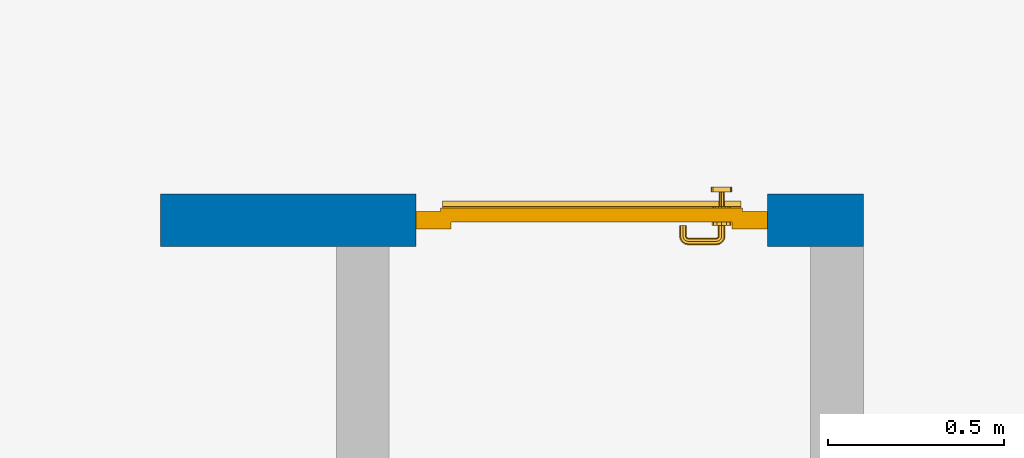
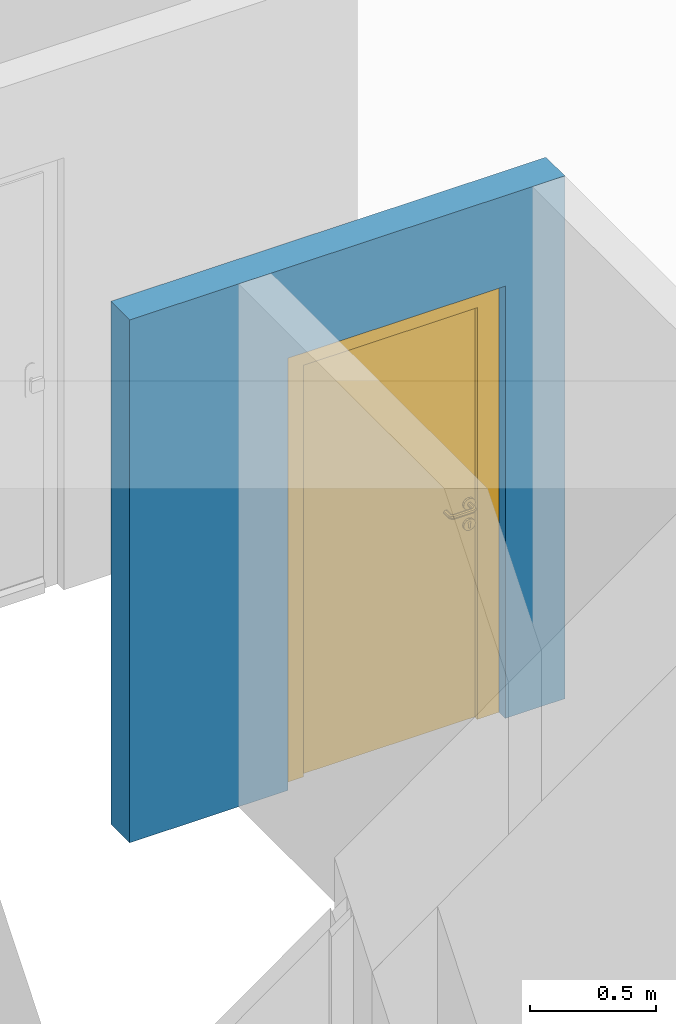
# One storey, part 23 of 54: 1 door, 1 wall, 1 opening.
"""IFC4 building model written with IfcOpenShell, lengths in metres."""

import ifcopenshell
import ifcopenshell.guid

model = None  # the IFC model being written
_history = None  # IfcOwnerHistory: only IFC2X3 demands one
_inside = {}  # id of a spatial element -> (the spatial element, [elements in it])
_under = {}  # id of a project, library or spatial element -> (it, [spatial elements below it])
_declared = {}  # id of a project -> (the project, [libraries it declares])
_typed = {}  # id of a type object -> (the type object, [elements of that type])
_made_of = {}  # id of a material, layer set ... -> (it, [elements and type objects made of it])


def new_model(schema):
    """Start an empty IFC model of exactly this schema.

    Asked for "IFC4X3", IfcOpenShell would pick the latest addendum, in which some entities
    have other attributes; the version numbers below select the first issue.
    IFC2X3 requires an IfcOwnerHistory on every rooted entity: one is made here for all.
    """
    global model, _history
    if schema == "IFC4X3":
        model = ifcopenshell.file(schema_version=(4, 3, 0, 0))
    else:
        model = ifcopenshell.file(schema=schema)
    _inside.clear()
    _under.clear()
    _declared.clear()
    _typed.clear()
    _made_of.clear()
    _history = None
    if model.schema == "IFC2X3":
        org = make("IfcOrganization", Name="unknown")
        user = make(
            "IfcPersonAndOrganization",
            ThePerson=make("IfcPerson", FamilyName="unknown"),
            TheOrganization=org,
        )
        app = make(
            "IfcApplication",
            ApplicationDeveloper=org,
            Version="unknown",
            ApplicationFullName="unknown",
            ApplicationIdentifier="unknown",
        )
        _history = make(
            "IfcOwnerHistory",
            OwningUser=user,
            OwningApplication=app,
            ChangeAction="ADDED",
            CreationDate=0,
        )
    return model


def make(cls, **values):
    """One entity of the class cls with the attributes given. An attribute that is None is left unset."""
    return model.create_entity(
        cls, **{name: value for name, value in values.items() if value is not None}
    )


def entity(cls, *values):
    """Any entity or typed value of the class cls, its attributes in the order of the schema. None: left unset."""
    e = model.create_entity(cls)
    for i, value in enumerate(values):
        if value is not None:
            e[i] = value
    return e


def rooted(cls, **values):
    """An entity with a GlobalId (a new one), such as an element, a storey or a relation."""
    return make(cls, GlobalId=ifcopenshell.guid.new(), OwnerHistory=_history, **values)


def si_unit(unit_type, name, prefix=None):
    """IfcSIUnit, for example si_unit("LENGTHUNIT", "METRE", prefix="MILLI")."""
    return make("IfcSIUnit", UnitType=unit_type, Prefix=prefix, Name=name)


def converted_unit(unit_type, name, factor, base, dimensions=None, offset=None):
    """IfcConversionBasedUnit, such as the inch: factor (a typed value) times the base unit."""
    return make(
        "IfcConversionBasedUnit"
        if offset is None
        else "IfcConversionBasedUnitWithOffset",
        ConversionOffset=offset,
        Dimensions=None
        if dimensions is None
        else entity("IfcDimensionalExponents", *dimensions),
        UnitType=unit_type,
        Name=name,
        ConversionFactor=make(
            "IfcMeasureWithUnit", ValueComponent=factor, UnitComponent=base
        ),
    )


def derived_unit(unit_type, elements):
    """IfcDerivedUnit: a product of units, each with its exponent."""
    return make(
        "IfcDerivedUnit",
        Elements=[
            make("IfcDerivedUnitElement", Unit=unit, Exponent=power)
            for unit, power in elements
        ],
        UnitType=unit_type,
    )


def assignment(units):
    """IfcUnitAssignment: the units of a project."""
    return None if units is None else make("IfcUnitAssignment", Units=units)


def point(xyz):
    """IfcCartesianPoint."""
    return None if xyz is None else make("IfcCartesianPoint", Coordinates=xyz)


def direction(xyz):
    """IfcDirection."""
    return None if xyz is None else make("IfcDirection", DirectionRatios=xyz)


def frame(location, z_axis=None, x_axis=None):
    """IfcAxis2Placement3D, a coordinate frame: its origin and axes. An axis left out is left unset."""
    return make(
        "IfcAxis2Placement3D",
        Location=point(location),
        Axis=direction(z_axis),
        RefDirection=direction(x_axis),
    )


def origin_with_axes():
    """The frame at (0, 0, 0) with the z axis (0, 0, 1) and the x axis (1, 0, 0) written out."""
    return frame((0.0, 0.0, 0.0), z_axis=(0.0, 0.0, 1.0), x_axis=(1.0, 0.0, 0.0))


def place(relative_to, where):
    """IfcLocalPlacement: puts the frame where relative to a parent placement (None: the world)."""
    return make(
        "IfcLocalPlacement", PlacementRelTo=relative_to, RelativePlacement=where
    )


def context(
    kind, dimensions, precision=None, world=None, true_north=None, identifier=None
):
    """IfcGeometricRepresentationContext, for example the 3D "Model" context."""
    return make(
        "IfcGeometricRepresentationContext",
        ContextIdentifier=identifier,
        ContextType=kind,
        CoordinateSpaceDimension=dimensions,
        Precision=precision,
        WorldCoordinateSystem=world,
        TrueNorth=true_north,
    )


def subcontext(parent, identifier, kind, view, scale=None):
    """IfcGeometricRepresentationSubContext, for example "Body" below "Model"."""
    return make(
        "IfcGeometricRepresentationSubContext",
        ContextIdentifier=identifier,
        ContextType=kind,
        ParentContext=parent,
        TargetScale=scale,
        TargetView=view,
    )


def project(units=None, contexts=None):
    """IfcProject with its units and contexts."""
    return rooted(
        "IfcProject",
        Name="project",
        RepresentationContexts=contexts,
        UnitsInContext=assignment(units),
    )


def spatial(cls, under=None, at=None, **own):
    """A site, building, storey or space (cls), placed at a placement, below another one or the project."""
    s = rooted(cls, ObjectPlacement=at, **own)
    if under is not None:
        _under.setdefault(under.id(), (under, []))[1].append(s)
    return s


def point_list(points):
    """IfcCartesianPointList2D or 3D."""
    cls = (
        "IfcCartesianPointList2D" if len(points[0]) == 2 else "IfcCartesianPointList3D"
    )
    return make(cls, CoordList=points)


def polygons(points, faces, closed=None, point_numbers=None):
    """IfcPolygonalFaceSet: a face is its outer loop, then its inner loops; points numbered from 1."""
    made = []
    for loops in faces:
        if len(loops) == 1:
            made.append(make("IfcIndexedPolygonalFace", CoordIndex=loops[0]))
        else:
            made.append(
                make(
                    "IfcIndexedPolygonalFaceWithVoids",
                    CoordIndex=loops[0],
                    InnerCoordIndices=loops[1:],
                )
            )
    return make(
        "IfcPolygonalFaceSet",
        Coordinates=point_list(points),
        Closed=closed,
        Faces=made,
        PnIndex=point_numbers,
    )


def shape(context_of_items, identifier, shape_type, items):
    """IfcShapeRepresentation: the items that make up one representation, for example the "Body"."""
    return make(
        "IfcShapeRepresentation",
        ContextOfItems=context_of_items,
        RepresentationIdentifier=identifier,
        RepresentationType=shape_type,
        Items=items,
    )


def source(mapping_origin, context_of_items, identifier, shape_type, items):
    """IfcRepresentationMap: a shape defined once, which mapped items show again and again."""
    return make(
        "IfcRepresentationMap",
        MappingOrigin=mapping_origin,
        MappedRepresentation=shape(context_of_items, identifier, shape_type, items),
    )


def transform(
    local_origin,
    x_axis=None,
    y_axis=None,
    z_axis=None,
    scale=None,
    scale2=None,
    scale3=None,
    uniform=True,
):
    """IfcCartesianTransformationOperator3D, or its non-uniform kind. x_axis, y_axis, z_axis: its Axis1, 2, 3."""
    if uniform:
        return make(
            "IfcCartesianTransformationOperator3D",
            Axis1=direction(x_axis),
            Axis2=direction(y_axis),
            LocalOrigin=point(local_origin),
            Scale=scale,
            Axis3=direction(z_axis),
        )
    return make(
        "IfcCartesianTransformationOperator3DnonUniform",
        Axis1=direction(x_axis),
        Axis2=direction(y_axis),
        LocalOrigin=point(local_origin),
        Scale=scale,
        Axis3=direction(z_axis),
        Scale2=scale2,
        Scale3=scale3,
    )


def mapped(mapping_source, mapping_target):
    """IfcMappedItem: shows the shape of a source again, moved by a transform."""
    return make(
        "IfcMappedItem", MappingSource=mapping_source, MappingTarget=mapping_target
    )


def material(Name=None, Category=None):
    """IfcMaterial."""
    return make("IfcMaterial", Name=Name, Category=Category)


def made_of(thing, what):
    """Note that an element or type object is made of a material, layer set ...; save() writes the relation."""
    if what is not None:
        _made_of.setdefault(what.id(), (what, []))[1].append(thing)
    return thing


def type_object(cls, material=None, **own):
    """A type object (cls), such as IfcWallType, which elements share."""
    return made_of(rooted(cls, **own), material)


def element(
    cls,
    number,
    at=None,
    inside=None,
    cuts=None,
    type_object=None,
    material=None,
    context=None,
    identifier="Body",
    shape_type=None,
    held_by="IfcProductDefinitionShape",
    body=None,
    shapes=None,
    **own,
):
    """One element of the class cls, such as IfcWall. Its Tag is "e" and its number.

    at: its placement. inside: the storey or other place that contains it. cuts: it is an
    opening in that element (IfcRelVoidsElement). A single representation is given by context,
    identifier, shape_type and body (its items); several are given by shapes. held_by: the class
    of the entity that holds the representations. save() writes the other relations.
    """
    e = rooted(cls, Tag="e%d" % number, ObjectPlacement=at, **own)
    if body is not None:
        shapes = [shape(context, identifier, shape_type, body)]
    if shapes is not None:
        e.Representation = make(held_by, Representations=shapes)
    if inside is not None:
        _inside.setdefault(inside.id(), (inside, []))[1].append(e)
    if cuts is not None:
        rooted(
            "IfcRelVoidsElement", RelatingBuildingElement=cuts, RelatedOpeningElement=e
        )
    if type_object is not None:
        _typed.setdefault(type_object.id(), (type_object, []))[1].append(e)
    return made_of(e, material)


def fill(opening, filler):
    """IfcRelFillsElement: the door or window that sits in an opening."""
    return rooted(
        "IfcRelFillsElement",
        RelatingOpeningElement=opening,
        RelatedBuildingElement=filler,
    )


def aggregate(whole, parts):
    """IfcRelAggregates: a whole, such as a stair, and the parts it consists of."""
    return rooted("IfcRelAggregates", RelatingObject=whole, RelatedObjects=parts)


def save(model, path):
    """Write the relations noted so far, then the file.

    IfcRelAggregates (storeys below a building ...), IfcRelContainedInSpatialStructure (elements
    in a storey), IfcRelDefinesByType, IfcRelAssociatesMaterial and IfcRelDeclares: one each for
    every whole, place, type object, material and project.
    """
    for whole, parts in _under.values():
        aggregate(whole, parts)
    for where, things in _inside.values():
        rooted(
            "IfcRelContainedInSpatialStructure",
            RelatedElements=things,
            RelatingStructure=where,
        )
    for kind, things in _typed.values():
        rooted("IfcRelDefinesByType", RelatedObjects=things, RelatingType=kind)
    for what, things in _made_of.values():
        rooted("IfcRelAssociatesMaterial", RelatedObjects=things, RelatingMaterial=what)
    for by, libraries in _declared.values():
        rooted("IfcRelDeclares", RelatingContext=by, RelatedDefinitions=libraries)
    model.write(path)


model = new_model("IFC4")

# Units and contexts
model_context = context("Model", 3, precision=1e-05, world=origin_with_axes(), true_north=direction((0.0, 1.0)))
body_context = subcontext(model_context, "Body", "Model", "MODEL_VIEW")
ifc_project = project(units=[si_unit("LENGTHUNIT", "METRE"), si_unit("AREAUNIT", "SQUARE_METRE"), si_unit("VOLUMEUNIT", "CUBIC_METRE"), converted_unit("PLANEANGLEUNIT", "DEGREE", entity("IfcPlaneAngleMeasure", 0.0174532925199), si_unit("PLANEANGLEUNIT", "RADIAN"), dimensions=[0, 0, 0, 0, 0, 0, 0]), converted_unit("TIMEUNIT", "Year", entity("IfcTimeMeasure", 31556926.0), si_unit("TIMEUNIT", "SECOND"), dimensions=[0, 0, 1, 0, 0, 0, 0]), si_unit("MASSUNIT", "GRAM", prefix="KILO"), si_unit("THERMODYNAMICTEMPERATUREUNIT", "DEGREE_CELSIUS"), si_unit("LUMINOUSINTENSITYUNIT", "LUMEN"), si_unit("ENERGYUNIT", "JOULE", prefix="MEGA"), derived_unit("THERMALCONDUCTANCEUNIT", [(si_unit("POWERUNIT", "WATT"), 1), (si_unit("LENGTHUNIT", "METRE"), -1), (si_unit("THERMODYNAMICTEMPERATUREUNIT", "KELVIN"), -1)]), derived_unit("SPECIFICHEATCAPACITYUNIT", [(si_unit("ENERGYUNIT", "JOULE"), 1), (si_unit("MASSUNIT", "GRAM", prefix="KILO"), -1), (si_unit("THERMODYNAMICTEMPERATUREUNIT", "KELVIN"), -1)]), derived_unit("MASSDENSITYUNIT", [(si_unit("MASSUNIT", "GRAM", prefix="KILO"), 1), (si_unit("VOLUMEUNIT", "CUBIC_METRE"), -1)])], contexts=[model_context])

# Site, building, storey
site_placement = place(None, origin_with_axes())
site = spatial("IfcSite", under=ifc_project, at=site_placement, CompositionType="ELEMENT")
building_placement = place(site_placement, origin_with_axes())
building = spatial("IfcBuilding", under=site, at=building_placement, CompositionType="ELEMENT")
storey_placement = place(building_placement, frame((0.0, 0.0, 6.29), z_axis=(0.0, 0.0, 1.0), x_axis=(1.0, 0.0, 0.0)))
storey = spatial("IfcBuildingStorey", under=building, at=storey_placement, Name="2. Geschoss", CompositionType="ELEMENT", Elevation=6.29)

# Wall, opening, door
ifc_material = material()
wall_type = type_object("IfcWallType", Name="150", PredefinedType="NOTDEFINED")
wall_placement = place(storey_placement, frame((4.6878006196, 3.97118776896, 0.0), z_axis=(0.0, 0.0, 1.0), x_axis=(-1.0, 0.0, 0.0)))
wall = element("IfcWall", 1, at=wall_placement, inside=storey, type_object=wall_type, material=ifc_material, Name="Wand-002", PredefinedType="NOTDEFINED", context=body_context, shape_type="Tessellation", body=[
    polygons([(0.12346205006, 0.05, 0.0), (0.12346205006, 0.05, 2.1), (0.12346205006, 0.0, 2.1), (0.12346205006, 0.0, 0.0), (0.12346205006, 0.15, 0.0), (0.12346205006, 0.15, 2.1), (1.12346205006, 0.05, 2.1), (1.12346205006, 0.0, 2.1), (-0.15, 0.0, 0.0), (1.12346205006, 0.0, 0.0), (1.85, 0.0, 0.0), (1.85, 0.0, 2.54), (-0.15, 0.0, 2.54), (-0.15, 0.15, 0.0), (-0.15, 0.15, 2.54), (1.85, 0.15, 2.54), (1.85, 0.15, 0.0), (1.12346205006, 0.15, 0.0), (1.12346205006, 0.15, 2.1), (1.12346205006, 0.05, 0.0)], [[[1, 2, 3, 4]], [[2, 1, 5, 6]], [[2, 7, 8, 3]], [[9, 4, 3, 8, 10, 11, 12, 13]], [[5, 1, 4, 9, 14]], [[6, 5, 14, 15, 16, 17, 18, 19]], [[7, 2, 6, 19]], [[7, 20, 10, 8]], [[20, 18, 17, 11, 10]], [[12, 11, 17, 16]], [[13, 12, 16, 15]], [[15, 14, 9, 13]], [[20, 7, 19, 18]]], closed=True),
])
opening_placement = place(wall_placement, frame((0.62346205006, 0.0, 0.0), z_axis=(0.0, 0.0, 1.0), x_axis=(1.0, 0.0, 0.0)))
opening = element("IfcOpeningElement", 2, at=opening_placement, cuts=wall, context=body_context, identifier="Reference", shape_type="Tessellation", body=[
    polygons([(0.5, 0.05, 0.0), (0.5, 0.05, 2.1), (0.5, -0.001, 2.1), (0.5, -0.001, 0.0), (0.5, 0.151, 0.0), (0.5, 0.151, 2.1), (-0.5, 0.05, 2.1), (-0.5, -0.001, 2.1), (-0.5, 0.151, 2.1), (-0.5, -0.001, 0.0), (-0.5, 0.05, 0.0), (-0.5, 0.151, 0.0)], [[[1, 2, 3, 4]], [[2, 1, 5, 6]], [[7, 8, 3, 2, 6, 9]], [[8, 10, 4, 3]], [[1, 4, 10, 11, 12, 5]], [[6, 5, 12, 9]], [[7, 11, 10, 8]], [[11, 7, 9, 12]]], closed=True),
])
door_type = type_object("IfcDoorType", Name="Eingang 01 1-Fl 26", OperationType="SINGLE_SWING_LEFT", PredefinedType="DOOR")
shared_shape = source(origin_with_axes(), body_context, "Body", "Tessellation", [
    polygons([(-0.5, -0.05, 0.0), (-0.5, -0.05, 2.1), (-0.5, -0.03, 2.1), (-0.5, -0.03, 0.0), (-0.4, -0.05, 0.0), (-0.4, -0.05, 2.0), (-0.1301, -0.05, 2.0), (-0.0001, -0.05, 2.0), (0.4, -0.05, 2.0), (0.4, -0.05, 0.0), (0.5, -0.05, 0.0), (0.5, -0.05, 2.1), (0.5, -0.03, 2.1), (0.5, -0.03, 0.0), (0.4, -0.03, 0.0), (0.4, -0.03, 2.0), (-0.0001, -0.03, 2.0), (-0.1301, -0.03, 2.0), (-0.4, -0.03, 2.0), (-0.4, -0.03, 0.0)], [[[1, 2, 3, 4]], [[1, 5, 6, 7, 8, 9, 10, 11, 12, 2]], [[2, 12, 13, 3]], [[4, 3, 13, 14, 15, 16, 17, 18, 19, 20]], [[5, 1, 4, 20]], [[6, 5, 20, 19]], [[7, 6, 19, 18]], [[8, 7, 18, 17]], [[9, 8, 17, 16]], [[10, 9, 16, 15]], [[11, 10, 15, 14]], [[12, 11, 14, 13]]], closed=True),
    polygons([(-0.5, -0.03, 0.0), (-0.5, -0.03, 2.1), (-0.5, 0.0, 2.1), (-0.5, 0.0, 0.0), (-0.43, -0.03, 0.0), (-0.43, -0.03, 2.03), (-0.1001, -0.03, 2.03), (-0.0301, -0.03, 2.03), (0.43, -0.03, 2.03), (0.43, -0.03, 0.0), (0.5, -0.03, 0.0), (0.5, -0.03, 2.1), (0.5, 0.0, 2.1), (0.5, 0.0, 0.0), (0.43, 0.0, 0.0), (0.43, 0.0, 2.03), (-0.0301, 0.0, 2.03), (-0.1001, 0.0, 2.03), (-0.43, 0.0, 2.03), (-0.43, 0.0, 0.0)], [[[1, 2, 3, 4]], [[1, 5, 6, 7, 8, 9, 10, 11, 12, 2]], [[2, 12, 13, 3]], [[4, 3, 13, 14, 15, 16, 17, 18, 19, 20]], [[5, 1, 4, 20]], [[6, 5, 20, 19]], [[7, 6, 19, 18]], [[8, 7, 18, 17]], [[9, 8, 17, 16]], [[10, 9, 16, 15]], [[11, 10, 15, 14]], [[12, 11, 14, 13]]], closed=True),
    polygons([(-0.43, 0.01, 0.0), (-0.43, 0.01, 2.03), (0.43, 0.01, 2.03), (0.43, 0.01, 0.0), (-0.43, -0.03, 0.0), (-0.43, -0.03, 2.03), (0.43, -0.03, 2.03), (0.43, -0.03, 0.0)], [[[1, 2, 3, 4]], [[1, 5, 6, 2]], [[2, 6, 7, 3]], [[3, 7, 8, 4]], [[4, 8, 5, 1]], [[8, 7, 6, 5]]], closed=True),
    polygons([(-0.425, 0.03, 0.0), (-0.425, 0.03, 0.05), (0.425, 0.03, 0.05), (0.425, 0.03, 0.0), (-0.425, 0.01, 0.0), (-0.425, 0.01, 0.07), (-0.425, 0.015, 0.07), (0.425, 0.015, 0.07), (0.425, 0.01, 0.07), (0.425, 0.01, 0.0)], [[[1, 2, 3, 4]], [[1, 5, 6, 7, 2]], [[2, 7, 8, 3]], [[4, 3, 8, 9, 10]], [[5, 1, 4, 10]], [[6, 5, 10, 9]], [[7, 6, 9, 8]]], closed=True),
    polygons([(0.3835, -0.04, 1.0733826859), (0.3835, -0.0399, 1.0733826859), (0.37, -0.0399, 1.077), (0.37, -0.04, 1.077), (0.393382685902, -0.04, 1.0635), (0.393382685902, -0.0399, 1.0635), (0.3835, -0.0301, 1.0733826859), (0.37, -0.0301, 1.077), (0.3565, -0.0399, 1.0733826859), (0.3565, -0.04, 1.0733826859), (0.346617314098, -0.04, 1.0635), (0.343, -0.04, 1.05), (0.346617314098, -0.04, 1.0365), (0.3565, -0.04, 1.0266173141), (0.37, -0.04, 1.023), (0.3835, -0.04, 1.0266173141), (0.393382685902, -0.04, 1.0365), (0.397, -0.04, 1.05), (0.397, -0.0399, 1.05), (0.393382685902, -0.0301, 1.0635), (0.3835, -0.03, 1.0733826859), (0.37, -0.03, 1.077), (0.3565, -0.0301, 1.0733826859), (0.346617314098, -0.0399, 1.0635), (0.343, -0.0399, 1.05), (0.346617314098, -0.0399, 1.0365), (0.3565, -0.0399, 1.0266173141), (0.37, -0.0399, 1.023), (0.3835, -0.0399, 1.0266173141), (0.393382685902, -0.0399, 1.0365), (0.397, -0.0301, 1.05), (0.393382685902, -0.03, 1.0635), (0.397, -0.03, 1.05), (0.393382685902, -0.03, 1.0365), (0.3835, -0.03, 1.0266173141), (0.37, -0.03, 1.023), (0.3565, -0.03, 1.0266173141), (0.346617314098, -0.03, 1.0365), (0.343, -0.03, 1.05), (0.346617314098, -0.03, 1.0635), (0.3565, -0.03, 1.0733826859), (0.346617314098, -0.0301, 1.0635), (0.343, -0.0301, 1.05), (0.346617314098, -0.0301, 1.0365), (0.3565, -0.0301, 1.0266173141), (0.37, -0.0301, 1.023), (0.3835, -0.0301, 1.0266173141), (0.393382685902, -0.0301, 1.0365)], [[[1, 2, 3, 4]], [[5, 6, 2, 1]], [[2, 7, 8, 3]], [[4, 3, 9, 10]], [[4, 10, 11, 12, 13, 14, 15, 16, 17, 18, 5, 1]], [[18, 19, 6, 5]], [[6, 20, 7, 2]], [[7, 21, 22, 8]], [[3, 8, 23, 9]], [[10, 9, 24, 11]], [[11, 24, 25, 12]], [[12, 25, 26, 13]], [[13, 26, 27, 14]], [[14, 27, 28, 15]], [[15, 28, 29, 16]], [[16, 29, 30, 17]], [[17, 30, 19, 18]], [[19, 31, 20, 6]], [[20, 32, 21, 7]], [[22, 21, 32, 33, 34, 35, 36, 37, 38, 39, 40, 41]], [[8, 22, 41, 23]], [[9, 23, 42, 24]], [[24, 42, 43, 25]], [[25, 43, 44, 26]], [[26, 44, 45, 27]], [[27, 45, 46, 28]], [[28, 46, 47, 29]], [[29, 47, 48, 30]], [[30, 48, 31, 19]], [[31, 33, 32, 20]], [[48, 34, 33, 31]], [[47, 35, 34, 48]], [[46, 36, 35, 47]], [[45, 37, 36, 46]], [[44, 38, 37, 45]], [[43, 39, 38, 44]], [[42, 40, 39, 43]], [[23, 41, 40, 42]]], closed=True),
    polygons([(0.362532169224, -0.04, 0.959692280177), (0.363279754556, -0.04, 0.961639806549), (0.35655, -0.04, 0.973296083362), (0.346703916638, -0.04, 0.96345), (0.365, -0.04, 0.952886751346), (0.365, -0.04, 0.9544), (0.362532169224, -0.039, 0.959692280177), (0.363279754556, -0.039, 0.961639806549), (0.364624817685, -0.039, 0.965143815798), (0.364624817685, -0.04, 0.965143815798), (0.37, -0.04, 0.967425445323), (0.37, -0.04, 0.9769), (0.346617314098, -0.04, 0.9635), (0.3565, -0.04, 0.973382685902), (0.365, -0.04, 0.95), (0.3431, -0.04, 0.95), (0.365, -0.04, 0.947113248654), (0.365, -0.04, 0.941339745962), (0.365, -0.04, 0.9375), (0.365, -0.039, 0.9375), (0.365, -0.039, 0.941339745962), (0.365, -0.039, 0.947113248654), (0.365, -0.039, 0.95), (0.365, -0.039, 0.952886751346), (0.365, -0.039, 0.9544), (0.347569942042, -0.039, 0.96295), (0.35705, -0.039, 0.972430057958), (0.37, -0.039, 0.9759), (0.37, -0.039, 0.967425445323), (0.375375182315, -0.04, 0.965143815798), (0.376720245444, -0.04, 0.961639806549), (0.38345, -0.04, 0.973296083362), (0.37, -0.04, 0.977), (0.343, -0.04, 0.95), (0.346617314098, -0.0399, 0.9635), (0.3565, -0.0399, 0.973382685902), (0.346703916638, -0.04, 0.93655), (0.35655, -0.04, 0.926703916638), (0.37, -0.04, 0.9231), (0.37, -0.04, 0.9325), (0.366464466094, -0.04, 0.933964466094), (0.366464466094, -0.039, 0.933964466094), (0.37, -0.039, 0.9241), (0.35705, -0.039, 0.927569942042), (0.37, -0.039, 0.9325), (0.347569942042, -0.039, 0.93705), (0.3441, -0.039, 0.95), (0.347483339502, -0.039, 0.963), (0.357, -0.039, 0.972516660498), (0.37, -0.039, 0.976), (0.375375182315, -0.039, 0.965143815798), (0.38295, -0.039, 0.972430057958), (0.376720245444, -0.039, 0.961639806549), (0.377467830776, -0.039, 0.959692280177), (0.377467830776, -0.04, 0.959692280177), (0.375, -0.04, 0.9544), (0.375, -0.04, 0.952886751346), (0.393296083362, -0.04, 0.96345), (0.3835, -0.04, 0.973382685902), (0.37, -0.0399, 0.977), (0.346617314098, -0.04, 0.9365), (0.343, -0.0399, 0.95), (0.346617314098, -0.0301, 0.9635), (0.3565, -0.0301, 0.973382685902), (0.3565, -0.04, 0.926617314098), (0.37, -0.04, 0.923), (0.38345, -0.04, 0.926703916638), (0.375, -0.04, 0.941339745962), (0.375, -0.04, 0.9375), (0.373535533906, -0.04, 0.933964466094), (0.37, -0.039, 0.924), (0.357, -0.039, 0.927483339502), (0.38295, -0.039, 0.927569942042), (0.373535533906, -0.039, 0.933964466094), (0.375, -0.039, 0.9375), (0.375, -0.039, 0.941339745962), (0.347483339502, -0.039, 0.937), (0.344, -0.039, 0.95), (0.347483339502, -0.0389, 0.963), (0.357, -0.0389, 0.972516660498), (0.37, -0.0389, 0.976), (0.383, -0.039, 0.972516660498), (0.392430057958, -0.039, 0.96295), (0.375, -0.039, 0.952886751346), (0.375, -0.039, 0.9544), (0.375, -0.039, 0.95), (0.375, -0.039, 0.947113248654), (0.375, -0.04, 0.947113248654), (0.375, -0.04, 0.95), (0.3969, -0.04, 0.95), (0.393382685902, -0.04, 0.9635), (0.3835, -0.0399, 0.973382685902), (0.37, -0.0301, 0.977), (0.346617314098, -0.0399, 0.9365), (0.343, -0.0301, 0.95), (0.346617314098, -0.03, 0.9635), (0.3565, -0.03, 0.973382685902), (0.3565, -0.0399, 0.926617314098), (0.3835, -0.04, 0.926617314098), (0.37, -0.0399, 0.923), (0.393296083362, -0.04, 0.93655), (0.383, -0.039, 0.927483339502), (0.37, -0.0389, 0.924), (0.357, -0.0389, 0.927483339502), (0.392430057958, -0.039, 0.93705), (0.347483339502, -0.0389, 0.937), (0.344, -0.0389, 0.95), (0.347483339502, -0.0301, 0.963), (0.357, -0.0301, 0.972516660498), (0.37, -0.0301, 0.976), (0.383, -0.0389, 0.972516660498), (0.392516660498, -0.039, 0.963), (0.3959, -0.039, 0.95), (0.397, -0.04, 0.95), (0.393382685902, -0.0399, 0.9635), (0.3835, -0.0301, 0.973382685902), (0.37, -0.03, 0.977), (0.346617314098, -0.0301, 0.9365), (0.343, -0.03, 0.95), (0.346703916638, -0.03, 0.96345), (0.35655, -0.03, 0.973296083362), (0.3565, -0.0301, 0.926617314098), (0.393382685902, -0.04, 0.9365), (0.3835, -0.0399, 0.926617314098), (0.37, -0.0301, 0.923), (0.392516660498, -0.039, 0.937), (0.383, -0.0389, 0.927483339502), (0.37, -0.0301, 0.924), (0.357, -0.0301, 0.927483339502), (0.347483339502, -0.0301, 0.937), (0.344, -0.0301, 0.95), (0.347483339502, -0.03, 0.963), (0.357, -0.03, 0.972516660498), (0.37, -0.03, 0.976), (0.383, -0.0301, 0.972516660498), (0.392516660498, -0.0389, 0.963), (0.396, -0.039, 0.95), (0.397, -0.0399, 0.95), (0.393382685902, -0.0301, 0.9635), (0.3835, -0.03, 0.973382685902), (0.37, -0.03, 0.9769), (0.346617314098, -0.03, 0.9365), (0.3431, -0.03, 0.95), (0.347396736961, -0.03, 0.96305), (0.35695, -0.03, 0.972603263039), (0.3565, -0.03, 0.926617314098), (0.393382685902, -0.0399, 0.9365), (0.3835, -0.0301, 0.926617314098), (0.37, -0.03, 0.923), (0.392516660498, -0.0389, 0.937), (0.383, -0.0301, 0.927483339502), (0.37, -0.03, 0.924), (0.357, -0.03, 0.927483339502), (0.347483339502, -0.03, 0.937), (0.344, -0.03, 0.95), (0.37, -0.03, 0.9761), (0.383, -0.03, 0.972516660498), (0.392516660498, -0.0301, 0.963), (0.396, -0.0389, 0.95), (0.397, -0.0301, 0.95), (0.393382685902, -0.03, 0.9635), (0.38345, -0.03, 0.973296083362), (0.346703916638, -0.03, 0.93655), (0.3439, -0.03, 0.95), (0.35655, -0.03, 0.926703916638), (0.393382685902, -0.0301, 0.9365), (0.3835, -0.03, 0.926617314098), (0.37, -0.03, 0.9231), (0.392516660498, -0.0301, 0.937), (0.383, -0.03, 0.927483339502), (0.37, -0.03, 0.9239), (0.35695, -0.03, 0.927396736961), (0.347396736961, -0.03, 0.93695), (0.38305, -0.03, 0.972603263039), (0.392516660498, -0.03, 0.963), (0.396, -0.0301, 0.95), (0.397, -0.03, 0.95), (0.393296083362, -0.03, 0.96345), (0.393382685902, -0.03, 0.9365), (0.38345, -0.03, 0.926703916638), (0.392516660498, -0.03, 0.937), (0.38305, -0.03, 0.927396736961), (0.392603263039, -0.03, 0.96305), (0.396, -0.03, 0.95), (0.3969, -0.03, 0.95), (0.393296083362, -0.03, 0.93655), (0.392603263039, -0.03, 0.93695), (0.3961, -0.03, 0.95)], [[[1, 2, 3, 4, 5, 6]], [[1, 7, 8, 9, 10, 2]], [[10, 11, 12, 3, 2]], [[13, 4, 3, 14]], [[15, 5, 4, 16]], [[6, 5, 15, 17, 18, 19, 20, 21, 22, 23, 24, 25]], [[6, 25, 7, 1]], [[7, 25, 24, 26, 27, 8]], [[9, 8, 27, 28, 29]], [[10, 9, 29, 11]], [[30, 31, 32, 12, 11]], [[14, 3, 12, 33]], [[34, 16, 4, 13]], [[35, 13, 14, 36]], [[17, 15, 16, 37]], [[18, 17, 37, 38]], [[38, 39, 40, 41, 19, 18]], [[19, 41, 42, 20]], [[43, 44, 21, 20, 42, 45]], [[22, 21, 44, 46]], [[23, 22, 46, 47]], [[24, 23, 47, 26]], [[26, 48, 49, 27]], [[27, 49, 50, 28]], [[51, 29, 28, 52, 53]], [[11, 29, 51, 30]], [[30, 51, 53, 54, 55, 31]], [[55, 56, 57, 58, 32, 31]], [[33, 12, 32, 59]], [[36, 14, 33, 60]], [[61, 37, 16, 34]], [[62, 34, 13, 35]], [[63, 35, 36, 64]], [[65, 38, 37, 61]], [[66, 39, 38, 65]], [[39, 67, 68, 69, 70, 40]], [[41, 40, 45, 42]], [[43, 71, 72, 44]], [[73, 43, 45, 74, 75, 76]], [[44, 72, 77, 46]], [[46, 77, 78, 47]], [[47, 78, 48, 26]], [[48, 79, 80, 49]], [[49, 80, 81, 50]], [[28, 50, 82, 52]], [[54, 53, 52, 83, 84, 85]], [[55, 54, 85, 56]], [[85, 84, 86, 87, 76, 75, 69, 68, 88, 89, 57, 56]], [[57, 89, 90, 58]], [[59, 32, 58, 91]], [[60, 33, 59, 92]], [[64, 36, 60, 93]], [[94, 61, 34, 62]], [[95, 62, 35, 63]], [[96, 63, 64, 97]], [[98, 65, 61, 94]], [[99, 67, 39, 66]], [[100, 66, 65, 98]], [[88, 68, 67, 101]], [[70, 69, 75, 74]], [[40, 70, 74, 45]], [[73, 102, 71, 43]], [[71, 103, 104, 72]], [[76, 87, 105, 73]], [[72, 104, 106, 77]], [[77, 106, 107, 78]], [[78, 107, 79, 48]], [[79, 108, 109, 80]], [[80, 109, 110, 81]], [[50, 81, 111, 82]], [[52, 82, 112, 83]], [[86, 84, 83, 113]], [[87, 86, 113, 105]], [[89, 88, 101, 90]], [[91, 58, 90, 114]], [[92, 59, 91, 115]], [[93, 60, 92, 116]], [[97, 64, 93, 117]], [[118, 94, 62, 95]], [[119, 95, 63, 96]], [[120, 96, 97, 121]], [[122, 98, 94, 118]], [[123, 101, 67, 99]], [[124, 99, 66, 100]], [[125, 100, 98, 122]], [[105, 126, 102, 73]], [[102, 127, 103, 71]], [[103, 128, 129, 104]], [[104, 129, 130, 106]], [[106, 130, 131, 107]], [[107, 131, 108, 79]], [[108, 132, 133, 109]], [[109, 133, 134, 110]], [[81, 110, 135, 111]], [[82, 111, 136, 112]], [[83, 112, 137, 113]], [[113, 137, 126, 105]], [[114, 90, 101, 123]], [[115, 91, 114, 138]], [[116, 92, 115, 139]], [[117, 93, 116, 140]], [[121, 97, 117, 141]], [[142, 118, 95, 119]], [[143, 119, 96, 120]], [[144, 120, 121, 145]], [[146, 122, 118, 142]], [[147, 123, 99, 124]], [[148, 124, 100, 125]], [[149, 125, 122, 146]], [[126, 150, 127, 102]], [[127, 151, 128, 103]], [[128, 152, 153, 129]], [[129, 153, 154, 130]], [[130, 154, 155, 131]], [[131, 155, 132, 108]], [[132, 144, 145, 133]], [[133, 145, 156, 134]], [[110, 134, 157, 135]], [[111, 135, 158, 136]], [[112, 136, 159, 137]], [[137, 159, 150, 126]], [[138, 114, 123, 147]], [[139, 115, 138, 160]], [[140, 116, 139, 161]], [[141, 117, 140, 162]], [[145, 121, 141, 156]], [[163, 142, 119, 143]], [[164, 143, 120, 144]], [[165, 146, 142, 163]], [[166, 147, 124, 148]], [[167, 148, 125, 149]], [[168, 149, 146, 165]], [[150, 169, 151, 127]], [[151, 170, 152, 128]], [[152, 171, 172, 153]], [[153, 172, 173, 154]], [[154, 173, 164, 155]], [[155, 164, 144, 132]], [[134, 156, 174, 157]], [[135, 157, 175, 158]], [[136, 158, 176, 159]], [[159, 176, 169, 150]], [[160, 138, 147, 166]], [[161, 139, 160, 177]], [[162, 140, 161, 178]], [[156, 141, 162, 174]], [[173, 163, 143, 164]], [[172, 165, 163, 173]], [[179, 166, 148, 167]], [[180, 167, 149, 168]], [[171, 168, 165, 172]], [[169, 181, 170, 151]], [[170, 182, 171, 152]], [[157, 174, 183, 175]], [[158, 175, 184, 176]], [[176, 184, 181, 169]], [[177, 160, 166, 179]], [[178, 161, 177, 185]], [[174, 162, 178, 183]], [[186, 179, 167, 180]], [[182, 180, 168, 171]], [[181, 187, 182, 170]], [[175, 183, 188, 184]], [[184, 188, 187, 181]], [[185, 177, 179, 186]], [[183, 178, 185, 188]], [[187, 186, 180, 182]], [[188, 185, 186, 187]]], closed=True),
    polygons([(0.38, -0.04, 1.05), (0.38, -0.0709849140336, 1.05), (0.377071067812, -0.070696439392, 1.04292893219), (0.377071067812, -0.04, 1.04292893219), (0.377071067812, -0.04, 1.05707106781), (0.377071067812, -0.070696439392, 1.05707106781), (0.378277987014, -0.0796420579258, 1.05), (0.375518993221, -0.0784992452783, 1.04292893219), (0.37, -0.07, 1.04), (0.37, -0.04, 1.04), (0.37, -0.04, 1.06), (0.37, -0.07, 1.06), (0.375518993221, -0.0784992452783, 1.05707106781), (0.372816199938, -0.0878161999379, 1.05), (0.370704557509, -0.0857045575088, 1.04292893219), (0.368858192988, -0.0757402514855, 1.04), (0.362928932188, -0.069303560608, 1.04292893219), (0.362928932188, -0.04, 1.04292893219), (0.362928932188, -0.04, 1.05707106781), (0.362928932188, -0.069303560608, 1.05707106781), (0.368858192988, -0.0757402514855, 1.06), (0.370704557509, -0.0857045575088, 1.05707106781), (0.364642057926, -0.0932779870137, 1.05), (0.363499245278, -0.0905189932208, 1.04292893219), (0.365606601718, -0.0806066017178, 1.04), (0.362197392755, -0.0729812576926, 1.04292893219), (0.36, -0.0690150859664, 1.05), (0.36, -0.04, 1.05), (0.362197392755, -0.0729812576926, 1.05707106781), (0.365606601718, -0.0806066017178, 1.06), (0.363499245278, -0.0905189932208, 1.05707106781), (0.355984914034, -0.095, 1.05), (0.355696439392, -0.0920710678119, 1.04292893219), (0.360740251485, -0.0838581929877, 1.04), (0.360508645927, -0.0755086459268, 1.04292893219), (0.359438398962, -0.0718384450452, 1.05), (0.360508645927, -0.0755086459268, 1.05707106781), (0.360740251485, -0.0838581929877, 1.06), (0.355696439392, -0.0920710678119, 1.05707106781), (0.274015085966, -0.095, 1.05), (0.274303560608, -0.0920710678119, 1.04292893219), (0.355, -0.085, 1.04), (0.357981257693, -0.0771973927545, 1.04292893219), (0.358397003498, -0.0733970034977, 1.05), (0.357981257693, -0.0771973927545, 1.05707106781), (0.355, -0.085, 1.06), (0.274303560608, -0.0920710678119, 1.05707106781), (0.265357942074, -0.0932779870137, 1.05), (0.266500754722, -0.0905189932208, 1.04292893219), (0.275, -0.085, 1.04), (0.354303560608, -0.0779289321881, 1.04292893219), (0.356838445045, -0.0744383989617, 1.05), (0.354303560608, -0.0779289321881, 1.05707106781), (0.275, -0.085, 1.06), (0.266500754722, -0.0905189932208, 1.05707106781), (0.257183800062, -0.0878161999379, 1.05), (0.259295442491, -0.0857045575088, 1.04292893219), (0.269259748515, -0.0838581929877, 1.04), (0.275696439392, -0.0779289321881, 1.04292893219), (0.354015085966, -0.075, 1.05), (0.275696439392, -0.0779289321881, 1.05707106781), (0.269259748515, -0.0838581929877, 1.06), (0.259295442491, -0.0857045575088, 1.05707106781), (0.251722012986, -0.0796420579258, 1.05), (0.254481006779, -0.0784992452783, 1.04292893219), (0.264393398282, -0.0806066017178, 1.04), (0.272018742307, -0.0771973927545, 1.04292893219), (0.275984914034, -0.075, 1.05), (0.272018742307, -0.0771973927545, 1.05707106781), (0.264393398282, -0.0806066017178, 1.06), (0.254481006779, -0.0784992452783, 1.05707106781), (0.25, -0.0709849140336, 1.05), (0.252928932188, -0.070696439392, 1.04292893219), (0.261141807012, -0.0757402514855, 1.04), (0.269491354073, -0.0755086459268, 1.04292893219), (0.273161554955, -0.0744383989617, 1.05), (0.269491354073, -0.0755086459268, 1.05707106781), (0.261141807012, -0.0757402514855, 1.06), (0.252928932188, -0.070696439392, 1.05707106781), (0.25, -0.04, 1.05), (0.252928932188, -0.04, 1.04292893219), (0.26, -0.07, 1.04), (0.267802607245, -0.0729812576926, 1.04292893219), (0.271602996502, -0.0733970034977, 1.05), (0.267802607245, -0.0729812576926, 1.05707106781), (0.26, -0.07, 1.06), (0.252928932188, -0.04, 1.05707106781), (0.26, -0.04, 1.06), (0.267071067812, -0.04, 1.05707106781), (0.27, -0.04, 1.05), (0.267071067812, -0.04, 1.04292893219), (0.26, -0.04, 1.04), (0.267071067812, -0.069303560608, 1.04292893219), (0.270561601038, -0.0718384450452, 1.05), (0.267071067812, -0.069303560608, 1.05707106781), (0.27, -0.0690150859664, 1.05)], [[[1, 2, 3, 4]], [[5, 6, 2, 1]], [[2, 7, 8, 3]], [[4, 3, 9, 10]], [[11, 12, 6, 5]], [[6, 13, 7, 2]], [[7, 14, 15, 8]], [[3, 8, 16, 9]], [[10, 9, 17, 18]], [[19, 20, 12, 11]], [[12, 21, 13, 6]], [[13, 22, 14, 7]], [[14, 23, 24, 15]], [[8, 15, 25, 16]], [[9, 16, 26, 17]], [[18, 17, 27, 28]], [[28, 27, 20, 19]], [[20, 29, 21, 12]], [[21, 30, 22, 13]], [[22, 31, 23, 14]], [[23, 32, 33, 24]], [[15, 24, 34, 25]], [[16, 25, 35, 26]], [[17, 26, 36, 27]], [[27, 36, 29, 20]], [[29, 37, 30, 21]], [[30, 38, 31, 22]], [[31, 39, 32, 23]], [[32, 40, 41, 33]], [[24, 33, 42, 34]], [[25, 34, 43, 35]], [[26, 35, 44, 36]], [[36, 44, 37, 29]], [[37, 45, 38, 30]], [[38, 46, 39, 31]], [[39, 47, 40, 32]], [[40, 48, 49, 41]], [[33, 41, 50, 42]], [[34, 42, 51, 43]], [[35, 43, 52, 44]], [[44, 52, 45, 37]], [[45, 53, 46, 38]], [[46, 54, 47, 39]], [[47, 55, 48, 40]], [[48, 56, 57, 49]], [[41, 49, 58, 50]], [[42, 50, 59, 51]], [[43, 51, 60, 52]], [[52, 60, 53, 45]], [[53, 61, 54, 46]], [[54, 62, 55, 47]], [[55, 63, 56, 48]], [[56, 64, 65, 57]], [[49, 57, 66, 58]], [[50, 58, 67, 59]], [[51, 59, 68, 60]], [[60, 68, 61, 53]], [[61, 69, 62, 54]], [[62, 70, 63, 55]], [[63, 71, 64, 56]], [[64, 72, 73, 65]], [[57, 65, 74, 66]], [[58, 66, 75, 67]], [[59, 67, 76, 68]], [[68, 76, 69, 61]], [[69, 77, 70, 62]], [[70, 78, 71, 63]], [[71, 79, 72, 64]], [[72, 80, 81, 73]], [[65, 73, 82, 74]], [[66, 74, 83, 75]], [[67, 75, 84, 76]], [[76, 84, 77, 69]], [[77, 85, 78, 70]], [[78, 86, 79, 71]], [[79, 87, 80, 72]], [[80, 87, 88, 89, 90, 91, 92, 81]], [[73, 81, 92, 82]], [[74, 82, 93, 83]], [[75, 83, 94, 84]], [[84, 94, 85, 77]], [[85, 95, 86, 78]], [[86, 88, 87, 79]], [[95, 89, 88, 86]], [[96, 90, 89, 95]], [[93, 91, 90, 96]], [[82, 92, 91, 93]], [[83, 93, 96, 94]], [[94, 96, 95, 85]]], closed=False),
    polygons([(0.364696699141, 0.015, 1.04469669914), (0.37, 0.015, 1.0425), (0.375303300859, 0.015, 1.04469669914), (0.3775, 0.015, 1.05), (0.375303300859, 0.015, 1.05530330086), (0.37, 0.015, 1.0575), (0.364696699141, 0.015, 1.05530330086), (0.3625, 0.015, 1.05), (0.364696699141, 0.055, 1.04469669914), (0.37, 0.055, 1.0425), (0.375303300859, 0.055, 1.04469669914), (0.3775, 0.055, 1.05), (0.375303300859, 0.055, 1.05530330086), (0.37, 0.055, 1.0575), (0.364696699141, 0.055, 1.05530330086), (0.3625, 0.055, 1.05)], [[[1, 2, 3, 4, 5, 6, 7, 8]], [[2, 1, 9, 10]], [[3, 2, 10, 11]], [[4, 3, 11, 12]], [[5, 4, 12, 13]], [[6, 5, 13, 14]], [[7, 6, 14, 15]], [[8, 7, 15, 16]], [[1, 8, 16, 9]], [[9, 16, 15, 14, 13, 12, 11, 10]]], closed=True),
    polygons([(0.395, 0.01, 0.975), (0.393096988313, 0.01, 0.965432914191), (0.393096988313, 0.015, 0.965432914191), (0.395, 0.015, 0.975), (0.395, 0.01, 1.1), (0.393096988313, 0.01, 1.10956708581), (0.38767766953, 0.01, 1.11767766953), (0.379567085809, 0.01, 1.12309698831), (0.37, 0.01, 1.125), (0.360432914191, 0.01, 1.12309698831), (0.35232233047, 0.01, 1.11767766953), (0.346903011687, 0.01, 1.10956708581), (0.345, 0.01, 1.1), (0.345, 0.01, 0.975), (0.346903011687, 0.01, 0.965432914191), (0.35232233047, 0.01, 0.95732233047), (0.360432914191, 0.01, 0.951903011687), (0.37, 0.01, 0.95), (0.379567085809, 0.01, 0.951903011687), (0.38767766953, 0.01, 0.95732233047), (0.38767766953, 0.015, 0.95732233047), (0.379567085809, 0.015, 0.951903011687), (0.37, 0.015, 0.95), (0.360432914191, 0.015, 0.951903011687), (0.35232233047, 0.015, 0.95732233047), (0.346903011687, 0.015, 0.965432914191), (0.345, 0.015, 0.975), (0.345, 0.015, 1.1), (0.346903011687, 0.015, 1.10956708581), (0.35232233047, 0.015, 1.11767766953), (0.360432914191, 0.015, 1.12309698831), (0.37, 0.015, 1.125), (0.379567085809, 0.015, 1.12309698831), (0.38767766953, 0.015, 1.11767766953), (0.393096988313, 0.015, 1.10956708581), (0.395, 0.015, 1.1)], [[[1, 2, 3, 4]], [[1, 5, 6, 7, 8, 9, 10, 11, 12, 13, 14, 15, 16, 17, 18, 19, 20, 2]], [[2, 20, 21, 3]], [[4, 3, 21, 22, 23, 24, 25, 26, 27, 28, 29, 30, 31, 32, 33, 34, 35, 36]], [[5, 1, 4, 36]], [[6, 5, 36, 35]], [[7, 6, 35, 34]], [[8, 7, 34, 33]], [[9, 8, 33, 32]], [[10, 9, 32, 31]], [[11, 10, 31, 30]], [[12, 11, 30, 29]], [[13, 12, 29, 28]], [[14, 13, 28, 27]], [[15, 14, 27, 26]], [[16, 15, 26, 25]], [[17, 16, 25, 24]], [[18, 17, 24, 23]], [[19, 18, 23, 22]], [[20, 19, 22, 21]]], closed=True),
    polygons([(0.39, 0.055, 1.08), (0.395, 0.055, 1.07866025404), (0.395, 0.07, 1.07866025404), (0.39, 0.07, 1.08), (0.35, 0.055, 1.08), (0.345, 0.055, 1.07866025404), (0.341339745962, 0.055, 1.075), (0.34, 0.055, 1.07), (0.34, 0.055, 1.03), (0.341339745962, 0.055, 1.025), (0.345, 0.055, 1.02133974596), (0.35, 0.055, 1.02), (0.39, 0.055, 1.02), (0.395, 0.055, 1.02133974596), (0.398660254038, 0.055, 1.025), (0.4, 0.055, 1.03), (0.4, 0.055, 1.07), (0.398660254038, 0.055, 1.075), (0.398660254038, 0.07, 1.075), (0.4, 0.07, 1.07), (0.4, 0.07, 1.03), (0.398660254038, 0.07, 1.025), (0.395, 0.07, 1.02133974596), (0.39, 0.07, 1.02), (0.35, 0.07, 1.02), (0.345, 0.07, 1.02133974596), (0.341339745962, 0.07, 1.025), (0.34, 0.07, 1.03), (0.34, 0.07, 1.07), (0.341339745962, 0.07, 1.075), (0.345, 0.07, 1.07866025404), (0.35, 0.07, 1.08)], [[[1, 2, 3, 4]], [[1, 5, 6, 7, 8, 9, 10, 11, 12, 13, 14, 15, 16, 17, 18, 2]], [[2, 18, 19, 3]], [[4, 3, 19, 20, 21, 22, 23, 24, 25, 26, 27, 28, 29, 30, 31, 32]], [[5, 1, 4, 32]], [[6, 5, 32, 31]], [[7, 6, 31, 30]], [[8, 7, 30, 29]], [[9, 8, 29, 28]], [[10, 9, 28, 27]], [[11, 10, 27, 26]], [[12, 11, 26, 25]], [[13, 12, 25, 24]], [[14, 13, 24, 23]], [[15, 14, 23, 22]], [[16, 15, 22, 21]], [[17, 16, 21, 20]], [[18, 17, 20, 19]]], closed=True),
])
door_placement = place(opening_placement, frame((0.4, 0.0, 0.0), z_axis=(0.0, 0.0, 1.0), x_axis=(-1.0, 0.0, 0.0)))
door = element("IfcDoor", 3, at=door_placement, inside=storey, type_object=door_type, OverallHeight=2.1, OverallWidth=1.0, PredefinedType="DOOR", context=body_context, shape_type="MappedRepresentation", body=[
    mapped(shared_shape, transform((0.4, -0.05, 0.0))),
])
fill(opening, door)

save(model, "model.ifc")
